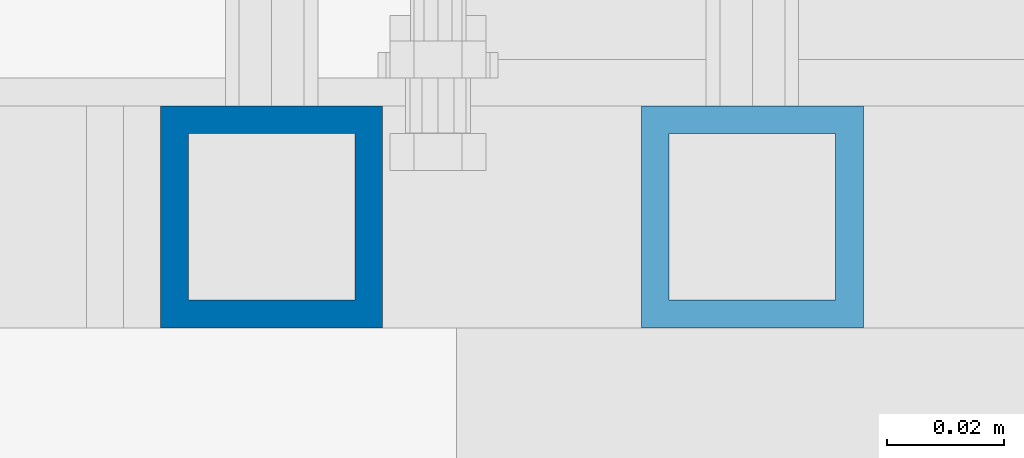
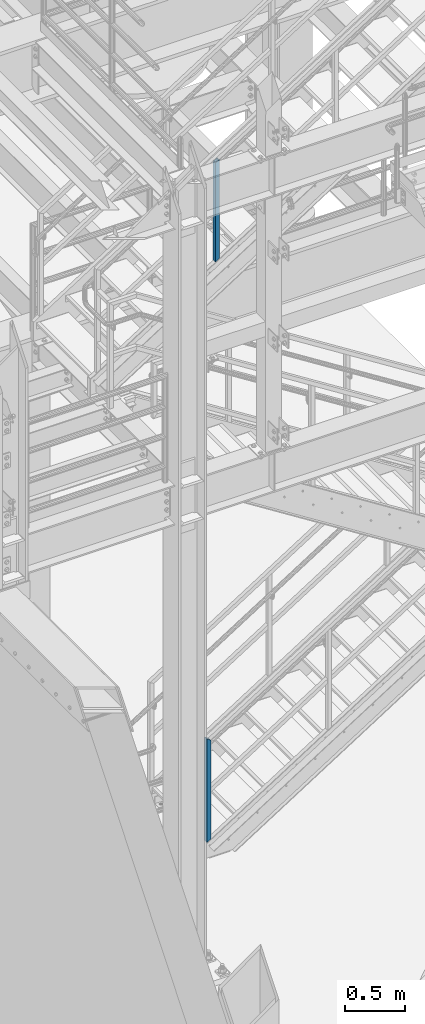
# One storey, part 604 of 1876: 2 columns, 2 elements without a shape of their own.
"""IFC2X3 building model written with IfcOpenShell, lengths in millimetres."""

from ifc_helpers import new_model, si_unit, frame, origin_with_axes, place, context, subcontext, project, spatial, faceted_brep, material, type_object, element, aggregate, save


model = new_model("IFC2X3")

# Units and contexts
model_context = context("Model", 3, precision=1e-05, world=origin_with_axes())
body_context = subcontext(model_context, "Body", "Model", "MODEL_VIEW")
ifc_project = project(units=[si_unit("LENGTHUNIT", "METRE", prefix="MILLI"), si_unit("AREAUNIT", "SQUARE_METRE"), si_unit("VOLUMEUNIT", "CUBIC_METRE"), si_unit("MASSUNIT", "GRAM", prefix="KILO"), si_unit("TIMEUNIT", "SECOND"), si_unit("PLANEANGLEUNIT", "RADIAN"), si_unit("SOLIDANGLEUNIT", "STERADIAN"), si_unit("THERMODYNAMICTEMPERATUREUNIT", "DEGREE_CELSIUS"), si_unit("LUMINOUSINTENSITYUNIT", "LUMEN")], contexts=[model_context])

# Site, building, storey
site_placement = place(None, origin_with_axes())
site = spatial("IfcSite", under=ifc_project, at=site_placement, CompositionType="ELEMENT")
building_placement = place(site_placement, origin_with_axes())
building = spatial("IfcBuilding", under=site, at=building_placement, Name="Undefined", CompositionType="ELEMENT")
storey_placement = place(building_placement, origin_with_axes())
storey = spatial("IfcBuildingStorey", under=building, at=storey_placement, Name="Undefined", CompositionType="ELEMENT", Elevation=0.0)

# Assembly, column
assembly_1_placement = place(storey_placement, origin_with_axes())
assembly_1 = element("IfcElementAssembly", 1, at=assembly_1_placement, inside=storey, Name="RAIL", AssemblyPlace="NOTDEFINED", PredefinedType="RIGID_FRAME")
ifc_material = material()
column_type = type_object("IfcColumnType", Name="HSS1-1/2X1-1/2X3/16", PredefinedType="NOTDEFINED")
column_1_placement = place(assembly_1_placement, frame((2743.20000001393, -5734.05000114554, 207.332759761854), z_axis=(-1.0, 0.0, 0.0), x_axis=(0.0, 0.0, 1.0)))
column_1 = element("IfcColumn", 2, at=column_1_placement, type_object=column_type, material=ifc_material, Name="POST", ObjectType="HSS1-1/2X1-1/2X3/16", context=body_context, shape_type="Brep", body=[
    faceted_brep([(9.06405233918804, 14.2874994260001, -14.2874994260001), (9.06405233918804, -14.2874994260001, -14.2874994260001), (1028.86378150912, -14.2874994260001, -14.2874994260001), (1028.86378150912, 14.2874994260001, -14.2874994260001), (-9.06405233919031, -14.2874994260001, 14.2874994260001), (1044.57587095721, -14.2874994260001, 14.2874994260001), (-9.06405233919031, 14.2874994260001, 14.2874994260001), (1044.57587095721, 14.2874994260001, 14.2874994260001), (12.0854031191295, 19.0499992349996, -19.0499992349996), (-12.0854031191318, 19.0499992349996, 19.0499992349996), (1047.19455253207, 19.0499992349996, 19.0499992350001), (1026.24509902744, 19.0499992349996, -19.0499992349996), (-12.0854031191318, -19.0499992349996, 19.0499992349996), (1047.19455253207, -19.0499992349996, 19.0499992350001), (12.0854031191295, -19.0499992349996, -19.0499992349996), (1026.24509902744, -19.0500000000002, -19.0499992349996)], [[[0, 1, 2, 3]], [[1, 4, 5, 2]], [[4, 6, 7, 5]], [[6, 0, 3, 7]], [[8, 9, 10, 11]], [[9, 12, 13, 10]], [[12, 14, 15, 13]], [[14, 8, 11, 15]], [[13, 15, 11, 10], [5, 7, 3, 2]], [[14, 12, 9, 8], [6, 4, 1, 0]]]),
])
aggregate(assembly_1, [column_1])

assembly_2_placement = place(storey_placement, origin_with_axes())
assembly_2 = element("IfcElementAssembly", 3, at=assembly_2_placement, inside=storey, Name="RAIL", AssemblyPlace="NOTDEFINED", PredefinedType="RIGID_FRAME")
column_2_placement = place(assembly_2_placement, frame((2825.74999791228, -5734.05000114554, 6111.96367809644), z_axis=(-1.0, 0.0, 0.0), x_axis=(0.0, 0.0, 1.0)))
column_2 = element("IfcColumn", 4, at=column_2_placement, type_object=column_type, material=ifc_material, Name="POST", ObjectType="HSS1-1/2X1-1/2X3/16", context=body_context, shape_type="Brep", body=[
    faceted_brep([(1026.23571825648, -19.0500000000002, -19.0499992349996), (1026.23571825648, 19.0499992349996, -19.0499992349996), (1001.99026470106, 19.0499992349996, 19.0499992349996), (1001.99026470106, -19.0499992349996, 19.0499992349996), (1023.20503656197, -14.2874994260001, -14.2874994260001), (1005.02094639574, -14.2874994260001, 14.2874994260001), (1005.02094639574, 14.2874994260001, 14.2874994260001), (1023.20503656197, 14.2874994260001, -14.2874994260001), (-12.1227267776903, 19.0499992349996, 19.0499992349996), (-12.1227267776903, -19.0499992349996, 19.0499992349996), (12.1227267777067, -19.0499992349996, -19.0499992349996), (12.1227267777067, 19.0499992349996, -19.0499992349996), (-9.09204508310631, 14.2874994260001, 14.2874994260001), (-9.09204508310631, -14.2874994260001, 14.2874994260001), (9.09204508312268, -14.2874994260001, -14.2874994260001), (9.09204508312268, 14.2874994260001, -14.2874994260001)], [[[0, 1, 2, 3], [4, 5, 6, 7]], [[8, 9, 3, 2]], [[9, 10, 0, 3]], [[10, 11, 1, 0]], [[11, 8, 2, 1]], [[10, 9, 8, 11], [12, 13, 14, 15]], [[15, 14, 4, 7]], [[12, 15, 7, 6]], [[13, 12, 6, 5]], [[14, 13, 5, 4]]]),
])
aggregate(assembly_2, [column_2])

save(model, "model.ifc")
